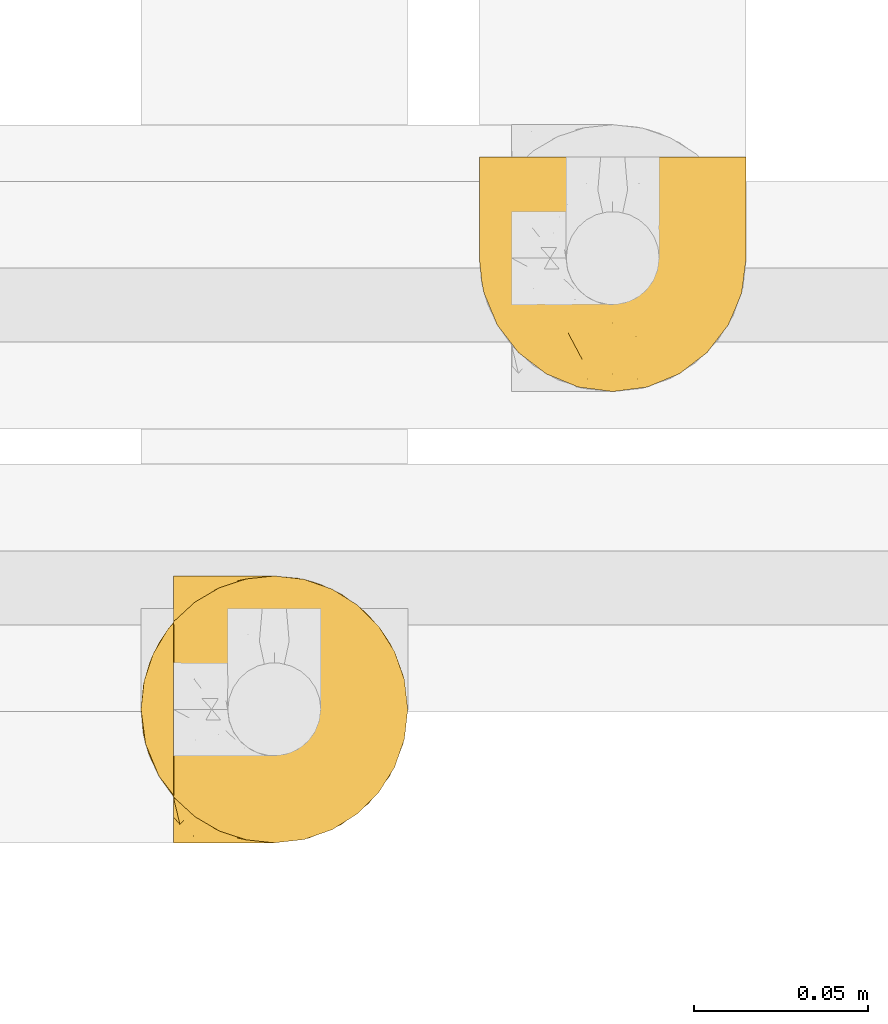
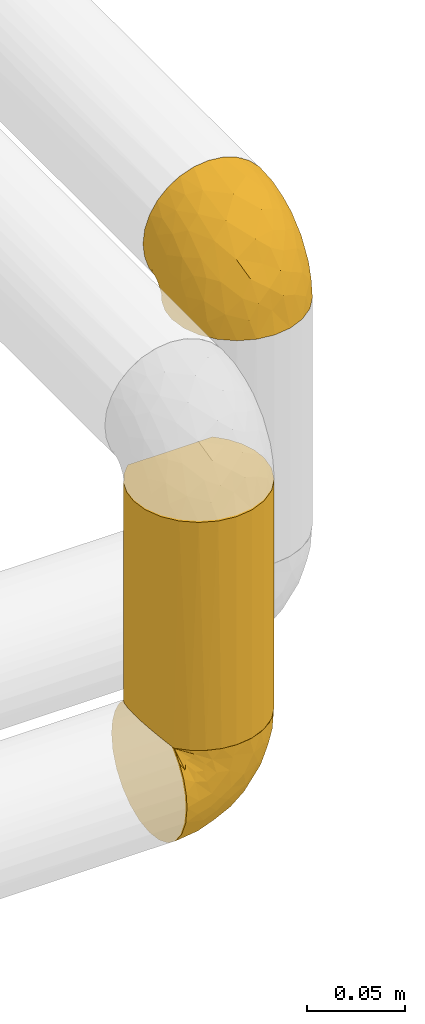
# One storey, part 90 of 827: 3 coverings.
"""IFC2X3 building model written with IfcOpenShell, lengths in millimetres."""

from ifc_helpers import new_model, entity, si_unit, converted_unit, derived_unit, direction, frame, origin, place, context, subcontext, project, spatial, faceted_brep, element, save


model = new_model("IFC2X3")

# Units and contexts
model_context = context("Model", 3, precision=0.01, world=origin(), true_north=direction((6.12303176911189e-17, 1.0)))
body_context = subcontext(model_context, "Body", "Model", "MODEL_VIEW")
ifc_project = project(units=[si_unit("LENGTHUNIT", "METRE", prefix="MILLI"), si_unit("AREAUNIT", "SQUARE_METRE"), si_unit("VOLUMEUNIT", "CUBIC_METRE"), converted_unit("PLANEANGLEUNIT", "DEGREE", entity("IfcRatioMeasure", 0.0174532925199433), si_unit("PLANEANGLEUNIT", "RADIAN"), dimensions=[0, 0, 0, 0, 0, 0, 0]), si_unit("MASSUNIT", "GRAM", prefix="KILO"), derived_unit("MASSDENSITYUNIT", [(si_unit("MASSUNIT", "GRAM", prefix="KILO"), 1), (si_unit("LENGTHUNIT", "METRE"), -3)]), derived_unit("MOMENTOFINERTIAUNIT", [(si_unit("LENGTHUNIT", "METRE"), 4)]), si_unit("TIMEUNIT", "SECOND"), si_unit("FREQUENCYUNIT", "HERTZ"), si_unit("THERMODYNAMICTEMPERATUREUNIT", "DEGREE_CELSIUS"), derived_unit("THERMALTRANSMITTANCEUNIT", [(si_unit("MASSUNIT", "GRAM", prefix="KILO"), 1), (si_unit("THERMODYNAMICTEMPERATUREUNIT", "KELVIN"), -1), (si_unit("TIMEUNIT", "SECOND"), -3)]), derived_unit("VOLUMETRICFLOWRATEUNIT", [(si_unit("LENGTHUNIT", "METRE"), 3), (si_unit("TIMEUNIT", "SECOND"), -1)]), derived_unit("MASSFLOWRATEUNIT", [(si_unit("MASSUNIT", "GRAM", prefix="KILO"), 1), (si_unit("TIMEUNIT", "SECOND"), -1)]), derived_unit("ROTATIONALFREQUENCYUNIT", [(si_unit("TIMEUNIT", "SECOND"), -1)]), si_unit("ELECTRICCURRENTUNIT", "AMPERE"), si_unit("ELECTRICVOLTAGEUNIT", "VOLT"), si_unit("POWERUNIT", "WATT"), si_unit("FORCEUNIT", "NEWTON", prefix="KILO"), si_unit("ILLUMINANCEUNIT", "LUX"), si_unit("LUMINOUSFLUXUNIT", "LUMEN"), si_unit("LUMINOUSINTENSITYUNIT", "CANDELA"), derived_unit("USERDEFINED", [(si_unit("MASSUNIT", "GRAM", prefix="KILO"), -1), (si_unit("LENGTHUNIT", "METRE"), -2), (si_unit("TIMEUNIT", "SECOND"), 3), (si_unit("LUMINOUSFLUXUNIT", "LUMEN"), 1)]), derived_unit("LINEARVELOCITYUNIT", [(si_unit("LENGTHUNIT", "METRE"), 1), (si_unit("TIMEUNIT", "SECOND"), -1)]), si_unit("PRESSUREUNIT", "PASCAL"), derived_unit("USERDEFINED", [(si_unit("LENGTHUNIT", "METRE"), -2), (si_unit("MASSUNIT", "GRAM", prefix="KILO"), 1), (si_unit("TIMEUNIT", "SECOND"), -2)]), derived_unit("LINEARFORCEUNIT", [(si_unit("MASSUNIT", "GRAM", prefix="KILO"), 1), (si_unit("LENGTHUNIT", "METRE"), 1), (si_unit("TIMEUNIT", "SECOND"), -2), (si_unit("LENGTHUNIT", "METRE"), -1)]), derived_unit("PLANARFORCEUNIT", [(si_unit("MASSUNIT", "GRAM", prefix="KILO"), 1), (si_unit("LENGTHUNIT", "METRE"), 1), (si_unit("TIMEUNIT", "SECOND"), -2), (si_unit("LENGTHUNIT", "METRE"), -2)])], contexts=[model_context])

# Site, building, storey
site_placement = place(None, origin())
site = spatial("IfcSite", under=ifc_project, at=site_placement, CompositionType="ELEMENT")
building_placement = place(site_placement, origin())
building = spatial("IfcBuilding", under=site, at=building_placement, CompositionType="ELEMENT")
storey_placement = place(building_placement, frame((0.0, 0.0, 28200.0)))
storey = spatial("IfcBuildingStorey", under=building, at=storey_placement, Name="08", CompositionType="ELEMENT", Elevation=28200.0)

# Coverings
covering_1_placement = place(storey_placement, frame((18643.01, 12909.95, 2569.3)))
element("IfcCovering", 1, at=covering_1_placement, inside=storey, Name=":ADSK_", ObjectType=":ADSK_", PredefinedType="INSULATION", context=body_context, shape_type="Brep", body=[
    faceted_brep([(5.41, 69.15, 47.38), (9.99, 69.15, 54.67), (16.08, 69.15, 60.76), (23.37, 69.15, 65.34), (31.49, 69.15, 68.18), (40.05, 69.15, 69.15), (48.61, 69.15, 68.18), (56.73, 69.15, 65.33), (64.02, 69.15, 60.75), (70.11, 69.15, 54.66), (74.69, 69.15, 47.37), (77.53, 69.15, 39.25), (78.5, 69.15, 30.7), (77.63, 69.15, 22.59), (75.08, 69.15, 14.86), (70.97, 69.15, 7.84), (65.47, 69.15, 1.85), (63.27, 69.15, 1.85), (61.53, 69.15, 1.85), (59.57, 69.15, 1.85), (57.6, 69.15, 1.85), (55.63, 69.15, 1.85), (53.67, 69.15, 1.85), (51.7, 69.15, 1.85), (49.73, 69.15, 1.85), (47.54, 69.15, 1.85), (45.34, 69.15, 1.85), (43.15, 69.15, 1.85), (40.96, 69.15, 1.85), (38.76, 69.15, 1.85), (36.57, 69.15, 1.85), (34.37, 69.15, 1.85), (32.18, 69.15, 1.85), (29.98, 69.15, 1.85), (27.79, 69.15, 1.85), (25.6, 69.15, 1.85), (23.4, 69.15, 1.85), (21.21, 69.15, 1.85), (19.01, 69.15, 1.85), (16.82, 69.15, 1.85), (14.62, 69.15, 1.85), (9.12, 69.15, 7.85), (5.0, 69.15, 14.88), (2.46, 69.15, 22.61), (1.6, 69.15, 30.7), (2.56, 69.15, 39.26), (65.47, 68.89, 1.6), (70.97, 62.89, 1.6), (75.09, 55.87, 1.6), (77.63, 48.14, 1.6), (78.5, 40.05, 1.6), (77.19, 30.09, 1.6), (73.34, 20.82, 1.6), (67.23, 12.86, 1.6), (59.27, 6.75, 1.6), (50.0, 2.91, 1.6), (40.05, 1.6, 1.6), (30.09, 2.91, 1.6), (20.82, 6.75, 1.6), (12.86, 12.86, 1.6), (6.75, 20.82, 1.6), (2.91, 30.09, 1.6), (1.6, 40.05, 1.6), (2.46, 48.14, 1.6), (5.0, 55.87, 1.6), (9.12, 62.89, 1.6), (14.62, 68.89, 1.6), (16.82, 68.89, 1.6), (17.8, 68.89, 1.6), (19.39, 68.89, 1.6), (20.98, 68.89, 1.6), (22.57, 68.89, 1.6), (24.16, 68.89, 1.6), (25.75, 68.89, 1.6), (27.33, 68.89, 1.6), (28.92, 68.89, 1.6), (30.51, 68.89, 1.6), (32.1, 68.89, 1.6), (33.69, 68.89, 1.6), (35.28, 68.89, 1.6), (36.87, 68.89, 1.6), (38.46, 68.89, 1.6), (40.05, 68.89, 1.6), (41.63, 68.89, 1.6), (43.22, 68.89, 1.6), (44.81, 68.89, 1.6), (46.4, 68.89, 1.6), (47.99, 68.89, 1.6), (49.58, 68.89, 1.6), (51.17, 68.89, 1.6), (52.76, 68.89, 1.6), (54.72, 68.89, 1.6), (56.69, 68.89, 1.6), (58.88, 68.89, 1.6), (61.08, 68.89, 1.6), (63.27, 68.89, 1.6), (37.77, 68.97, 1.78), (36.07, 68.96, 1.77), (32.96, 68.97, 1.78), (31.36, 68.97, 1.77), (56.52, 68.98, 1.79), (54.96, 68.97, 1.78), (18.75, 68.96, 1.76), (58.07, 68.96, 1.77), (50.37, 68.96, 1.77), (23.36, 68.96, 1.76), (24.95, 68.96, 1.77), (42.43, 68.96, 1.77), (15.97, 69.0, 1.8), (51.96, 68.96, 1.76), (53.47, 68.96, 1.77), (48.63, 68.97, 1.78), (63.93, 68.96, 1.77), (40.93, 68.96, 1.77), (29.72, 68.96, 1.76), (62.4, 68.97, 1.77), (60.92, 68.97, 1.78), (17.31, 68.97, 1.77), (21.74, 68.96, 1.77), (34.56, 68.96, 1.77), (20.18, 68.97, 1.78), (14.62, 68.97, 1.77), (14.62, 69.02, 1.8), (14.62, 69.08, 1.82), (65.47, 68.97, 1.77), (65.47, 68.94, 1.72), (59.5, 68.96, 1.76), (47.1, 68.96, 1.77), (45.61, 68.95, 1.76), (28.18, 68.96, 1.77), (14.62, 68.92, 1.66), (14.62, 68.94, 1.72), (26.61, 68.98, 1.78), (65.47, 69.08, 1.82), (65.47, 69.02, 1.8), (39.32, 68.96, 1.77), (44.12, 68.97, 1.78), (65.47, 68.92, 1.66), (72.26, 61.33, 3.72), (76.57, 53.1, 7.41), (71.77, 63.33, 6.13), (77.9, 55.53, 19.34), (76.56, 63.33, 17.64), (78.5, 54.6, 26.8), (78.5, 41.99, 8.87), (75.52, 57.07, 9.2), (76.13, 57.95, 12.79), (77.81, 51.56, 14.62), (78.5, 41.58, 7.34), (72.4, 61.7, 5.33), (71.77, 65.0, 7.7), (72.25, 67.02, 9.41), (78.5, 61.87, 28.75), (78.5, 49.27, 21.47), (78.5, 43.94, 16.15), (75.75, 61.21, 14.14), (78.5, 63.4, 29.16), (50.46, 33.11, 57.02), (52.75, 52.82, 64.92), (40.05, 43.3, 64.0), (77.7, 33.73, 11.92), (77.66, 36.52, 19.16), (71.02, 24.87, 28.65), (63.45, 14.17, 24.62), (70.55, 18.43, 15.19), (75.57, 28.67, 18.36), (75.57, 26.0, 9.2), (72.61, 49.25, 46.98), (72.61, 59.72, 50.24), (67.24, 55.1, 56.1), (77.74, 44.72, 28.97), (57.43, 34.15, 54.46), (47.19, 5.25, 21.34), (54.76, 6.75, 18.4), (40.05, 55.54, 66.44), (63.45, 10.47, 12.07), (60.1, 25.49, 45.49), (63.72, 35.53, 50.57), (76.83, 48.22, 36.04), (76.34, 58.71, 42.07), (60.51, 57.42, 62.12), (72.59, 34.84, 37.37), (76.05, 36.87, 29.39), (66.15, 45.01, 53.59), (60.51, 44.4, 58.06), (51.88, 23.96, 49.27), (55.34, 11.2, 29.63), (48.67, 10.56, 33.21), (53.89, 16.81, 40.1), (46.73, 17.38, 44.08), (40.05, 21.38, 49.36), (40.05, 32.34, 56.68), (40.05, 4.3, 15.2), (63.95, 20.65, 35.57), (67.24, 29.66, 41.7), (69.62, 39.6, 46.4), (73.6, 42.55, 41.41), (40.05, 6.74, 27.45), (40.05, 14.06, 38.4), (4.52, 26.84, 12.99), (32.72, 5.28, 21.33), (27.18, 18.52, 42.89), (29.63, 33.13, 57.04), (12.86, 55.1, 56.11), (19.59, 57.43, 62.13), (9.54, 20.72, 21.89), (16.64, 11.46, 16.62), (17.48, 17.69, 32.9), (7.49, 49.26, 46.99), (7.49, 59.73, 50.25), (3.75, 58.71, 42.08), (20.75, 29.72, 49.91), (2.33, 35.35, 15.6), (1.6, 43.94, 16.15), (1.6, 41.99, 8.87), (1.6, 63.4, 29.16), (26.94, 4.93, 13.16), (9.54, 17.46, 10.83), (31.21, 10.94, 33.8), (25.33, 8.92, 25.02), (27.35, 52.83, 64.92), (8.17, 29.34, 32.83), (4.3, 30.26, 20.56), (19.59, 44.4, 58.07), (2.23, 39.06, 21.46), (2.45, 43.06, 28.1), (1.6, 54.6, 26.8), (1.6, 49.27, 21.47), (12.86, 42.69, 51.29), (3.27, 48.2, 36.04), (1.6, 61.87, 28.75), (2.29, 33.44, 8.45), (12.86, 29.67, 41.73), (6.89, 38.5, 39.27), (12.43, 23.35, 33.56), (4.1, 34.97, 27.29), (3.53, 53.1, 7.41), (6.88, 59.68, 3.51), (8.16, 62.19, 4.68), (9.02, 64.11, 5.52), (5.0, 57.97, 8.75), (3.96, 57.95, 12.79), (3.52, 63.33, 17.65), (2.4, 51.77, 13.9), (7.83, 67.02, 9.42), (8.32, 64.98, 7.68), (2.19, 55.53, 19.33), (4.34, 61.22, 14.13)], [[[0, 1, 2, 3, 4, 5, 6, 7, 8, 9, 10, 11, 12, 13, 14, 15, 16, 17, 18, 19, 20, 21, 22, 23, 24, 25, 26, 27, 28, 29, 30, 31, 32, 33, 34, 35, 36, 37, 38, 39, 40, 41, 42, 43, 44, 45]], [[46, 47, 48, 49, 50, 51, 52, 53, 54, 55, 56, 57, 58, 59, 60, 61, 62, 63, 64, 65, 66, 67, 68, 69, 70, 71, 72, 73, 74, 75, 76, 77, 78, 79, 80, 81, 82, 83, 84, 85, 86, 87, 88, 89, 90, 91, 92, 93, 94, 95]], [[96, 97, 30]], [[98, 77, 99]], [[100, 101, 21]], [[69, 68, 102]], [[20, 19, 103]], [[24, 23, 104]], [[20, 103, 100]], [[72, 105, 106]], [[84, 83, 107]], [[89, 88, 104]], [[108, 67, 66]], [[109, 110, 90]], [[111, 25, 24]], [[112, 17, 16]], [[82, 113, 83]], [[109, 23, 22]], [[114, 76, 75]], [[105, 36, 106]], [[104, 111, 24]], [[18, 115, 116]], [[97, 96, 80]], [[67, 108, 117]], [[105, 71, 118]], [[31, 97, 119]], [[102, 120, 69]], [[108, 121, 122, 123, 40]], [[112, 95, 115]], [[17, 115, 18]], [[94, 116, 115]], [[117, 68, 67]], [[38, 117, 39]], [[112, 124, 125]], [[17, 112, 115]], [[70, 120, 118]], [[39, 117, 108]], [[120, 38, 37]], [[120, 37, 118]], [[120, 70, 69]], [[116, 94, 126]], [[127, 86, 128]], [[117, 38, 102]], [[74, 129, 75]], [[99, 33, 32]], [[115, 95, 94]], [[39, 108, 40]], [[108, 66, 130, 131]], [[105, 72, 71]], [[118, 37, 36]], [[71, 70, 118]], [[35, 106, 36]], [[36, 105, 118]], [[35, 132, 106]], [[74, 73, 132]], [[106, 132, 73]], [[99, 114, 33]], [[132, 35, 34]], [[73, 72, 106]], [[95, 112, 46]], [[112, 16, 133, 134, 124]], [[129, 114, 75]], [[99, 76, 114]], [[114, 129, 33]], [[34, 33, 129]], [[78, 77, 98]], [[98, 119, 78]], [[129, 132, 34]], [[132, 129, 74]], [[79, 97, 80]], [[98, 99, 32]], [[98, 32, 31]], [[77, 76, 99]], [[97, 79, 119]], [[135, 96, 29]], [[30, 97, 31]], [[135, 29, 28]], [[81, 80, 96]], [[29, 96, 30]], [[31, 119, 98]], [[119, 79, 78]], [[96, 135, 81]], [[82, 81, 135]], [[113, 107, 83]], [[84, 107, 136]], [[107, 27, 136]], [[113, 28, 107]], [[27, 107, 28]], [[85, 84, 136]], [[136, 27, 26]], [[113, 135, 28]], [[135, 113, 82]], [[109, 89, 104]], [[86, 85, 128]], [[89, 109, 90]], [[111, 87, 127]], [[26, 128, 136]], [[88, 111, 104]], [[25, 111, 127]], [[22, 110, 109]], [[23, 109, 104]], [[110, 91, 90]], [[100, 92, 101]], [[110, 22, 101]], [[91, 110, 101]], [[116, 19, 18]], [[111, 88, 87]], [[126, 103, 19]], [[25, 127, 26]], [[86, 127, 87]], [[127, 128, 26]], [[136, 128, 85]], [[120, 102, 38]], [[117, 102, 68]], [[91, 101, 92]], [[21, 101, 22]], [[93, 92, 103]], [[100, 21, 20]], [[100, 103, 92]], [[126, 93, 103]], [[93, 126, 94]], [[116, 126, 19]], [[137, 138, 47]], [[48, 138, 139]], [[140, 125, 124]], [[141, 142, 143]], [[144, 49, 139]], [[145, 140, 146]], [[48, 139, 49]], [[139, 145, 147]], [[49, 144, 148, 50]], [[137, 125, 149]], [[14, 13, 142]], [[150, 146, 140]], [[149, 140, 145]], [[151, 150, 134]], [[151, 14, 142]], [[16, 15, 133]], [[13, 152, 142]], [[124, 150, 140]], [[141, 143, 153]], [[14, 151, 15]], [[15, 151, 133]], [[47, 46, 137]], [[139, 154, 144]], [[138, 48, 47]], [[125, 140, 149]], [[134, 133, 151]], [[146, 155, 141]], [[145, 146, 147]], [[149, 139, 138]], [[147, 153, 154]], [[147, 146, 141]], [[139, 147, 154]], [[139, 149, 145]], [[149, 138, 137]], [[147, 141, 153]], [[146, 150, 155]], [[151, 155, 150]], [[142, 141, 155]], [[13, 12, 156, 152]], [[152, 143, 142]], [[151, 142, 155]], [[150, 124, 134]], [[157, 158, 159]], [[160, 154, 161]], [[162, 163, 164]], [[165, 166, 160]], [[167, 168, 169]], [[153, 170, 161]], [[156, 12, 11]], [[158, 157, 171]], [[172, 55, 173]], [[158, 6, 174]], [[175, 54, 53]], [[52, 166, 164]], [[52, 164, 53]], [[54, 175, 173]], [[166, 52, 51]], [[176, 177, 171]], [[178, 143, 179]], [[156, 11, 179]], [[8, 7, 180]], [[169, 9, 8]], [[179, 143, 152, 156]], [[179, 11, 10]], [[168, 179, 10]], [[181, 162, 182]], [[179, 167, 178]], [[183, 184, 177]], [[183, 169, 184]], [[176, 171, 185]], [[172, 186, 187]], [[158, 7, 6]], [[159, 158, 174]], [[184, 180, 158]], [[54, 173, 55]], [[180, 169, 8]], [[188, 189, 187]], [[9, 168, 10]], [[186, 188, 187]], [[190, 157, 159, 191]], [[55, 172, 192]], [[176, 193, 194]], [[161, 170, 182]], [[162, 164, 165]], [[175, 164, 163]], [[51, 50, 148]], [[167, 195, 196]], [[178, 182, 170]], [[6, 5, 174]], [[158, 180, 7]], [[169, 180, 184]], [[169, 168, 9]], [[179, 168, 167]], [[182, 162, 165]], [[162, 194, 193]], [[161, 165, 160]], [[195, 181, 196]], [[192, 172, 197]], [[192, 56, 55]], [[189, 190, 198]], [[198, 197, 187]], [[172, 187, 197]], [[185, 189, 188]], [[198, 187, 189]], [[186, 172, 173]], [[173, 163, 186]], [[193, 186, 163]], [[176, 185, 188]], [[185, 157, 190]], [[188, 186, 193]], [[177, 176, 194]], [[188, 193, 176]], [[162, 193, 163]], [[195, 177, 194]], [[171, 177, 184]], [[181, 195, 194]], [[183, 167, 169]], [[162, 181, 194]], [[196, 182, 178]], [[158, 171, 184]], [[171, 157, 185]], [[177, 195, 183]], [[167, 183, 195]], [[182, 196, 181]], [[178, 170, 143]], [[178, 167, 196]], [[164, 175, 53]], [[173, 175, 163]], [[160, 51, 148]], [[164, 166, 165]], [[51, 160, 166]], [[160, 148, 144, 154]], [[153, 161, 154]], [[182, 165, 161]], [[190, 189, 185]], [[143, 170, 153]], [[60, 199, 61]], [[197, 200, 192]], [[201, 190, 202]], [[200, 57, 192]], [[203, 204, 2]], [[205, 206, 207]], [[208, 209, 210]], [[211, 207, 201]], [[212, 213, 214]], [[45, 215, 210]], [[216, 206, 58]], [[45, 44, 215]], [[59, 217, 60]], [[60, 217, 199]], [[0, 45, 210]], [[218, 201, 219]], [[202, 159, 220]], [[205, 221, 222]], [[223, 204, 203]], [[1, 203, 2]], [[57, 200, 216]], [[220, 3, 204]], [[220, 174, 4]], [[1, 0, 209]], [[212, 224, 213]], [[225, 226, 227]], [[228, 223, 203]], [[208, 210, 229]], [[210, 226, 229]], [[3, 220, 4]], [[58, 206, 59]], [[209, 203, 1]], [[202, 220, 223]], [[228, 203, 208]], [[202, 211, 201]], [[3, 2, 204]], [[202, 190, 191, 159]], [[210, 215, 230, 226]], [[199, 212, 231]], [[232, 233, 221]], [[233, 208, 229]], [[207, 206, 219]], [[217, 206, 205]], [[227, 224, 225]], [[233, 232, 228]], [[201, 207, 219]], [[234, 232, 221]], [[218, 219, 200]], [[202, 223, 211]], [[174, 220, 159]], [[174, 5, 4]], [[61, 231, 62]], [[220, 204, 223]], [[210, 209, 0]], [[203, 209, 208]], [[225, 233, 229]], [[224, 227, 213]], [[221, 233, 235]], [[57, 56, 192]], [[198, 218, 197]], [[200, 219, 216]], [[201, 198, 190]], [[197, 218, 200]], [[198, 201, 218]], [[206, 216, 219]], [[58, 57, 216]], [[231, 212, 214]], [[222, 212, 199]], [[228, 211, 223]], [[207, 211, 232]], [[62, 231, 214]], [[199, 231, 61]], [[233, 228, 208]], [[211, 228, 232]], [[222, 221, 235]], [[234, 205, 207]], [[206, 217, 59]], [[199, 217, 205]], [[205, 222, 199]], [[224, 222, 235]], [[222, 224, 212]], [[224, 235, 225]], [[233, 225, 235]], [[226, 225, 229]], [[205, 234, 221]], [[207, 232, 234]], [[63, 214, 236]], [[214, 213, 236]], [[214, 63, 62]], [[237, 236, 238]], [[238, 131, 130]], [[236, 237, 64]], [[239, 240, 241]], [[63, 236, 64]], [[130, 66, 65]], [[237, 130, 65]], [[242, 230, 43]], [[237, 65, 64]], [[239, 121, 131]], [[42, 242, 43]], [[241, 240, 243]], [[41, 123, 244]], [[43, 230, 215, 44]], [[244, 122, 245]], [[227, 246, 243]], [[241, 247, 245]], [[121, 239, 245]], [[41, 40, 123]], [[131, 238, 239]], [[244, 42, 41]], [[130, 237, 238]], [[240, 239, 238]], [[245, 239, 241]], [[247, 241, 246]], [[247, 244, 245]], [[238, 236, 240]], [[243, 236, 213]], [[236, 243, 240]], [[227, 226, 246]], [[243, 213, 227]], [[242, 246, 226]], [[243, 246, 241]], [[246, 242, 247]], [[244, 247, 242]], [[242, 226, 230]], [[42, 244, 242]], [[122, 244, 123]], [[122, 121, 245]], [[112, 125, 137, 46]], [[108, 131, 121]]]),
])
covering_2_placement = place(storey_placement, frame((18545.56, 12780.0, 2427.5)))
element("IfcCovering", 2, at=covering_2_placement, inside=storey, Name=":ADSK_", ObjectType=":ADSK_", PredefinedType="INSULATION", context=body_context, shape_type="Brep", body=[
    faceted_brep([(23.98, 5.09, 1.6), (16.91, 9.31, 1.6), (10.9, 14.94, 1.6), (10.9, 65.05, 1.6), (16.91, 70.68, 1.6), (23.98, 74.9, 1.6), (31.79, 77.51, 1.6), (40.0, 78.4, 1.6), (49.93, 77.09, 1.6), (59.2, 73.25, 1.6), (67.15, 67.15, 1.6), (73.25, 59.2, 1.6), (77.09, 49.93, 1.6), (78.4, 40.0, 1.6), (77.09, 30.06, 1.6), (73.25, 20.8, 1.6), (67.15, 12.84, 1.6), (59.2, 6.74, 1.6), (49.93, 2.9, 1.6), (40.0, 1.6, 1.6), (31.79, 2.48, 1.6), (2.9, 30.06, 143.4), (6.74, 20.8, 143.4), (12.84, 12.84, 143.4), (20.8, 6.74, 143.4), (30.06, 2.9, 143.4), (40.0, 1.6, 143.4), (49.93, 2.9, 143.4), (59.2, 6.74, 143.4), (67.15, 12.84, 143.4), (73.25, 20.8, 143.4), (77.09, 30.06, 143.4), (78.4, 40.0, 143.4), (77.51, 48.2, 143.4), (74.9, 56.01, 143.4), (70.68, 63.08, 143.4), (65.05, 69.1, 143.4), (14.94, 69.1, 143.4), (9.31, 63.08, 143.4), (5.09, 56.01, 143.4), (2.48, 48.2, 143.4), (1.6, 40.0, 143.4), (46.78, 77.79, 134.7), (53.36, 76.0, 136.5), (59.51, 73.07, 139.42), (40.0, 78.4, 134.1), (4.0, 26.63, 8.5), (2.2, 33.21, 10.29), (1.6, 40.0, 10.9), (6.92, 20.48, 5.57), (2.2, 46.78, 10.29), (4.0, 53.36, 8.5), (6.92, 59.51, 5.57), (20.48, 73.07, 139.42), (26.63, 76.0, 136.5), (33.21, 77.79, 134.7)], [[[0, 1, 2, 3, 4, 5, 6, 7, 8, 9, 10, 11, 12, 13, 14, 15, 16, 17, 18, 19, 20]], [[21, 22, 23, 24, 25, 26, 27, 28, 29, 30, 31, 32, 33, 34, 35, 36, 37, 38, 39, 40, 41]], [[42, 43, 8]], [[44, 36, 9]], [[43, 44, 9]], [[45, 42, 7]], [[7, 42, 8]], [[43, 9, 8]], [[36, 10, 9]], [[11, 35, 34]], [[12, 34, 33]], [[13, 33, 32]], [[10, 35, 11]], [[11, 34, 12]], [[33, 13, 12]], [[35, 10, 36]], [[14, 13, 32, 31]], [[15, 14, 31, 30]], [[30, 29, 16, 15]], [[18, 17, 28, 27]], [[19, 18, 27, 26]], [[29, 28, 17, 16]], [[20, 26, 25]], [[0, 25, 24]], [[1, 24, 23]], [[19, 26, 20]], [[20, 25, 0]], [[24, 1, 0]], [[23, 2, 1]], [[46, 22, 21]], [[21, 41, 47]], [[48, 47, 41]], [[49, 2, 22]], [[47, 46, 21]], [[49, 22, 46]], [[22, 2, 23]], [[50, 41, 40]], [[51, 40, 39]], [[52, 39, 38]], [[50, 48, 41]], [[52, 51, 39]], [[3, 52, 38]], [[50, 40, 51]], [[38, 37, 3]], [[37, 53, 4]], [[54, 55, 6]], [[53, 54, 5]], [[4, 53, 5]], [[55, 7, 6]], [[6, 5, 54]], [[7, 55, 45]], [[37, 4, 3]], [[50, 51, 52, 3, 2, 49, 46, 47, 48]], [[43, 42, 45, 55, 54, 53, 37, 36, 44]]]),
])
covering_3_placement = place(storey_placement, frame((18554.86, 12779.95, 2359.95)))
element("IfcCovering", 3, at=covering_3_placement, inside=storey, Name=":ADSK_", ObjectType=":ADSK_", PredefinedType="INSULATION", context=body_context, shape_type="Brep", body=[
    faceted_brep([(47.38, 5.41, 69.15), (54.67, 9.99, 69.15), (60.76, 16.08, 69.15), (65.34, 23.37, 69.15), (68.18, 31.49, 69.15), (69.15, 40.05, 69.15), (68.18, 48.61, 69.15), (65.33, 56.73, 69.15), (60.75, 64.02, 69.15), (54.66, 70.11, 69.15), (47.37, 74.69, 69.15), (39.25, 77.53, 69.15), (30.7, 78.5, 69.15), (22.59, 77.63, 69.15), (14.86, 75.08, 69.15), (7.84, 70.97, 69.15), (1.85, 65.47, 69.15), (1.85, 63.27, 69.15), (1.85, 61.53, 69.15), (1.85, 59.57, 69.15), (1.85, 57.6, 69.15), (1.85, 55.63, 69.15), (1.85, 53.67, 69.15), (1.85, 51.7, 69.15), (1.85, 49.73, 69.15), (1.85, 47.54, 69.15), (1.85, 45.34, 69.15), (1.85, 43.15, 69.15), (1.85, 40.96, 69.15), (1.85, 38.76, 69.15), (1.85, 36.57, 69.15), (1.85, 34.37, 69.15), (1.85, 32.18, 69.15), (1.85, 29.98, 69.15), (1.85, 27.79, 69.15), (1.85, 25.6, 69.15), (1.85, 23.4, 69.15), (1.85, 21.21, 69.15), (1.85, 19.01, 69.15), (1.85, 16.82, 69.15), (1.85, 14.62, 69.15), (7.85, 9.12, 69.15), (14.88, 5.0, 69.15), (22.61, 2.46, 69.15), (30.7, 1.6, 69.15), (39.26, 2.56, 69.15), (1.6, 65.47, 68.89), (1.6, 70.97, 62.89), (1.6, 75.09, 55.87), (1.6, 77.63, 48.14), (1.6, 78.5, 40.05), (1.6, 77.19, 30.09), (1.6, 73.34, 20.82), (1.6, 67.23, 12.86), (1.6, 59.27, 6.75), (1.6, 50.0, 2.91), (1.6, 40.05, 1.6), (1.6, 30.09, 2.91), (1.6, 20.82, 6.75), (1.6, 12.86, 12.86), (1.6, 6.75, 20.82), (1.6, 2.91, 30.09), (1.6, 1.6, 40.05), (1.6, 2.46, 48.14), (1.6, 5.0, 55.87), (1.6, 9.12, 62.89), (1.6, 14.62, 68.89), (1.6, 16.82, 68.89), (1.6, 17.8, 68.89), (1.6, 19.39, 68.89), (1.6, 20.98, 68.89), (1.6, 22.57, 68.89), (1.6, 24.16, 68.89), (1.6, 25.75, 68.89), (1.6, 27.33, 68.89), (1.6, 28.92, 68.89), (1.6, 30.51, 68.89), (1.6, 32.1, 68.89), (1.6, 33.69, 68.89), (1.6, 35.28, 68.89), (1.6, 36.87, 68.89), (1.6, 38.46, 68.89), (1.6, 40.05, 68.89), (1.6, 41.63, 68.89), (1.6, 43.22, 68.89), (1.6, 44.81, 68.89), (1.6, 46.4, 68.89), (1.6, 47.99, 68.89), (1.6, 49.58, 68.89), (1.6, 51.17, 68.89), (1.6, 52.76, 68.89), (1.6, 54.72, 68.89), (1.6, 56.69, 68.89), (1.6, 58.88, 68.89), (1.6, 61.08, 68.89), (1.6, 63.27, 68.89), (1.78, 37.77, 68.97), (1.77, 36.07, 68.96), (1.78, 32.96, 68.97), (1.77, 31.36, 68.97), (1.79, 56.52, 68.98), (1.78, 54.96, 68.97), (1.76, 18.75, 68.96), (1.77, 58.07, 68.96), (1.77, 50.37, 68.96), (1.76, 23.36, 68.96), (1.77, 24.95, 68.96), (1.77, 42.43, 68.96), (1.8, 15.97, 69.0), (1.76, 51.96, 68.96), (1.77, 53.47, 68.96), (1.78, 48.63, 68.97), (1.77, 63.93, 68.96), (1.77, 40.93, 68.96), (1.76, 29.72, 68.96), (1.77, 62.4, 68.97), (1.78, 60.92, 68.97), (1.77, 17.31, 68.97), (1.77, 21.74, 68.96), (1.77, 34.56, 68.96), (1.78, 20.18, 68.97), (1.77, 14.62, 68.97), (1.8, 14.62, 69.02), (1.82, 14.62, 69.08), (1.77, 65.47, 68.97), (1.72, 65.47, 68.94), (1.66, 65.47, 68.92), (1.76, 59.5, 68.96), (1.77, 47.1, 68.96), (1.76, 45.61, 68.95), (1.77, 28.18, 68.96), (1.66, 14.62, 68.92), (1.72, 14.62, 68.94), (1.78, 26.61, 68.98), (1.82, 65.47, 69.08), (1.8, 65.47, 69.02), (1.77, 39.32, 68.96), (1.78, 44.12, 68.97), (3.72, 72.26, 61.33), (7.41, 76.57, 53.1), (6.13, 71.77, 63.33), (21.47, 78.5, 49.27), (19.34, 77.9, 55.53), (26.8, 78.5, 54.6), (8.87, 78.5, 41.99), (9.2, 75.52, 57.07), (12.79, 76.13, 57.95), (14.62, 77.81, 51.56), (7.34, 78.5, 41.58), (5.33, 72.4, 61.7), (17.64, 76.56, 63.33), (7.7, 71.77, 65.0), (9.41, 72.25, 67.02), (28.75, 78.5, 61.87), (16.15, 78.5, 43.94), (14.14, 75.75, 61.21), (29.16, 78.5, 63.4), (57.02, 50.46, 33.11), (64.92, 52.75, 52.82), (64.0, 40.05, 43.3), (11.92, 77.7, 33.73), (19.16, 77.66, 36.52), (28.65, 71.02, 24.87), (24.62, 63.45, 14.17), (15.19, 70.55, 18.43), (18.36, 75.57, 28.67), (9.2, 75.57, 26.0), (46.98, 72.61, 49.25), (50.24, 72.61, 59.72), (56.1, 67.24, 55.1), (28.97, 77.74, 44.72), (54.46, 57.43, 34.15), (21.34, 47.19, 5.25), (18.4, 54.76, 6.75), (66.44, 40.05, 55.54), (12.07, 63.45, 10.47), (45.49, 60.1, 25.49), (50.57, 63.72, 35.53), (36.04, 76.83, 48.22), (42.07, 76.34, 58.71), (62.12, 60.51, 57.42), (37.37, 72.59, 34.84), (29.39, 76.05, 36.87), (53.59, 66.15, 45.01), (58.06, 60.51, 44.4), (49.27, 51.88, 23.96), (29.63, 55.34, 11.2), (33.21, 48.67, 10.56), (40.1, 53.89, 16.81), (44.08, 46.73, 17.38), (49.36, 40.05, 21.38), (56.68, 40.05, 32.34), (15.2, 40.05, 4.3), (35.57, 63.95, 20.65), (41.7, 67.24, 29.66), (46.4, 69.62, 39.6), (41.41, 73.6, 42.55), (27.45, 40.05, 6.74), (38.4, 40.05, 14.06), (12.99, 4.52, 26.84), (21.33, 32.72, 5.28), (42.89, 27.18, 18.52), (57.04, 29.63, 33.13), (56.11, 12.86, 55.1), (62.13, 19.59, 57.43), (21.89, 9.54, 20.72), (16.62, 16.64, 11.46), (32.9, 17.48, 17.69), (46.99, 7.49, 49.26), (50.25, 7.49, 59.73), (42.08, 3.75, 58.71), (49.91, 20.75, 29.72), (15.6, 2.33, 35.35), (16.15, 1.6, 43.94), (8.87, 1.6, 41.99), (29.16, 1.6, 63.4), (13.16, 26.94, 4.93), (10.83, 9.54, 17.46), (33.8, 31.21, 10.94), (25.02, 25.33, 8.92), (64.92, 27.35, 52.83), (32.83, 8.17, 29.34), (20.56, 4.3, 30.26), (58.07, 19.59, 44.4), (21.46, 2.23, 39.06), (28.1, 2.45, 43.06), (26.8, 1.6, 54.6), (21.47, 1.6, 49.27), (51.29, 12.86, 42.69), (36.04, 3.27, 48.2), (28.75, 1.6, 61.87), (8.45, 2.29, 33.44), (41.73, 12.86, 29.67), (39.27, 6.89, 38.5), (33.56, 12.43, 23.35), (27.29, 4.1, 34.97), (7.41, 3.53, 53.1), (3.51, 6.88, 59.68), (4.68, 8.16, 62.19), (5.52, 9.02, 64.11), (8.75, 5.0, 57.97), (12.79, 3.96, 57.95), (17.65, 3.52, 63.33), (13.9, 2.4, 51.77), (9.42, 7.83, 67.02), (7.68, 8.32, 64.98), (19.33, 2.19, 55.53), (14.13, 4.34, 61.22)], [[[0, 1, 2, 3, 4, 5, 6, 7, 8, 9, 10, 11, 12, 13, 14, 15, 16, 17, 18, 19, 20, 21, 22, 23, 24, 25, 26, 27, 28, 29, 30, 31, 32, 33, 34, 35, 36, 37, 38, 39, 40, 41, 42, 43, 44, 45]], [[46, 47, 48, 49, 50, 51, 52, 53, 54, 55, 56, 57, 58, 59, 60, 61, 62, 63, 64, 65, 66, 67, 68, 69, 70, 71, 72, 73, 74, 75, 76, 77, 78, 79, 80, 81, 82, 83, 84, 85, 86, 87, 88, 89, 90, 91, 92, 93, 94, 95]], [[96, 97, 30]], [[98, 77, 99]], [[100, 101, 21]], [[69, 68, 102]], [[20, 19, 103]], [[24, 23, 104]], [[20, 103, 100]], [[72, 105, 106]], [[84, 83, 107]], [[89, 88, 104]], [[108, 67, 66]], [[109, 110, 90]], [[111, 25, 24]], [[112, 17, 16]], [[82, 113, 83]], [[109, 23, 22]], [[114, 76, 75]], [[105, 36, 106]], [[104, 111, 24]], [[18, 115, 116]], [[97, 96, 80]], [[67, 108, 117]], [[105, 71, 118]], [[31, 97, 119]], [[102, 120, 69]], [[108, 121, 122, 123, 40]], [[112, 95, 115]], [[17, 115, 18]], [[94, 116, 115]], [[117, 68, 67]], [[38, 117, 39]], [[112, 124, 125, 126, 46]], [[17, 112, 115]], [[70, 120, 118]], [[39, 117, 108]], [[120, 38, 37]], [[120, 37, 118]], [[120, 70, 69]], [[116, 94, 127]], [[128, 86, 129]], [[117, 38, 102]], [[74, 130, 75]], [[99, 33, 32]], [[115, 95, 94]], [[39, 108, 40]], [[108, 66, 131, 132, 121]], [[105, 72, 71]], [[118, 37, 36]], [[71, 70, 118]], [[35, 106, 36]], [[36, 105, 118]], [[35, 133, 106]], [[74, 73, 133]], [[106, 133, 73]], [[99, 114, 33]], [[133, 35, 34]], [[73, 72, 106]], [[95, 112, 46]], [[112, 16, 134, 135, 124]], [[130, 114, 75]], [[99, 76, 114]], [[114, 130, 33]], [[34, 33, 130]], [[78, 77, 98]], [[98, 119, 78]], [[130, 133, 34]], [[133, 130, 74]], [[79, 97, 80]], [[98, 99, 32]], [[98, 32, 31]], [[77, 76, 99]], [[97, 79, 119]], [[136, 96, 29]], [[30, 97, 31]], [[136, 29, 28]], [[81, 80, 96]], [[29, 96, 30]], [[31, 119, 98]], [[119, 79, 78]], [[96, 136, 81]], [[82, 81, 136]], [[113, 107, 83]], [[84, 107, 137]], [[107, 27, 137]], [[113, 28, 107]], [[27, 107, 28]], [[85, 84, 137]], [[137, 27, 26]], [[113, 136, 28]], [[136, 113, 82]], [[109, 89, 104]], [[86, 85, 129]], [[89, 109, 90]], [[111, 87, 128]], [[26, 129, 137]], [[88, 111, 104]], [[25, 111, 128]], [[22, 110, 109]], [[23, 109, 104]], [[110, 91, 90]], [[100, 92, 101]], [[110, 22, 101]], [[91, 110, 101]], [[116, 19, 18]], [[111, 88, 87]], [[127, 103, 19]], [[25, 128, 26]], [[86, 128, 87]], [[128, 129, 26]], [[137, 129, 85]], [[120, 102, 38]], [[117, 102, 68]], [[91, 101, 92]], [[21, 101, 22]], [[93, 92, 103]], [[100, 21, 20]], [[100, 103, 92]], [[127, 93, 103]], [[93, 127, 94]], [[116, 127, 19]], [[126, 138, 47]], [[48, 138, 139]], [[140, 125, 124]], [[141, 142, 143]], [[144, 49, 139]], [[145, 140, 146]], [[48, 139, 49]], [[139, 145, 147]], [[49, 144, 148, 50]], [[126, 125, 149]], [[14, 13, 150]], [[151, 146, 140]], [[149, 140, 145]], [[152, 151, 135]], [[152, 14, 150]], [[16, 15, 134]], [[13, 153, 150]], [[124, 151, 140]], [[141, 147, 142]], [[14, 152, 15]], [[15, 152, 134]], [[47, 46, 126]], [[139, 154, 144]], [[138, 48, 47]], [[125, 140, 149]], [[135, 134, 152]], [[146, 155, 142]], [[145, 146, 147]], [[149, 139, 138]], [[147, 141, 154]], [[147, 146, 142]], [[139, 147, 154]], [[139, 149, 145]], [[149, 138, 126]], [[155, 146, 151]], [[150, 143, 142]], [[152, 155, 151]], [[150, 142, 155]], [[13, 12, 156, 153]], [[153, 143, 150]], [[152, 150, 155]], [[151, 124, 135]], [[157, 158, 159]], [[160, 154, 161]], [[162, 163, 164]], [[165, 166, 160]], [[167, 168, 169]], [[141, 170, 161]], [[156, 12, 11]], [[158, 157, 171]], [[172, 55, 173]], [[158, 6, 174]], [[175, 54, 53]], [[52, 166, 164]], [[52, 164, 53]], [[54, 175, 173]], [[166, 52, 51]], [[176, 177, 171]], [[178, 143, 179]], [[156, 11, 179]], [[8, 7, 180]], [[169, 9, 8]], [[179, 143, 153, 156]], [[179, 11, 10]], [[168, 179, 10]], [[181, 162, 182]], [[179, 167, 178]], [[183, 184, 177]], [[183, 169, 184]], [[176, 171, 185]], [[172, 186, 187]], [[158, 7, 6]], [[159, 158, 174]], [[184, 180, 158]], [[54, 173, 55]], [[180, 169, 8]], [[188, 189, 187]], [[9, 168, 10]], [[186, 188, 187]], [[190, 157, 159, 191]], [[55, 172, 192]], [[176, 193, 194]], [[161, 170, 182]], [[162, 164, 165]], [[175, 164, 163]], [[51, 50, 148]], [[167, 195, 196]], [[178, 182, 170]], [[6, 5, 174]], [[158, 180, 7]], [[169, 180, 184]], [[169, 168, 9]], [[179, 168, 167]], [[182, 162, 165]], [[162, 194, 193]], [[161, 165, 160]], [[195, 181, 196]], [[192, 172, 197]], [[192, 56, 55]], [[189, 190, 198]], [[198, 197, 187]], [[172, 187, 197]], [[185, 189, 188]], [[198, 187, 189]], [[186, 172, 173]], [[173, 163, 186]], [[193, 186, 163]], [[176, 185, 188]], [[185, 157, 190]], [[188, 186, 193]], [[177, 176, 194]], [[188, 193, 176]], [[162, 193, 163]], [[195, 177, 194]], [[171, 177, 184]], [[181, 195, 194]], [[183, 167, 169]], [[162, 181, 194]], [[196, 182, 178]], [[158, 171, 184]], [[171, 157, 185]], [[177, 195, 183]], [[167, 183, 195]], [[182, 196, 181]], [[178, 170, 143]], [[178, 167, 196]], [[164, 175, 53]], [[173, 175, 163]], [[160, 51, 148]], [[164, 166, 165]], [[51, 160, 166]], [[160, 148, 144, 154]], [[141, 161, 154]], [[182, 165, 161]], [[190, 189, 185]], [[143, 170, 141]], [[60, 199, 61]], [[197, 200, 192]], [[201, 190, 202]], [[200, 57, 192]], [[203, 204, 2]], [[205, 206, 207]], [[208, 209, 210]], [[211, 207, 201]], [[212, 213, 214]], [[45, 215, 210]], [[216, 206, 58]], [[45, 44, 215]], [[59, 217, 60]], [[60, 217, 199]], [[0, 45, 210]], [[218, 201, 219]], [[202, 159, 220]], [[205, 221, 222]], [[223, 204, 203]], [[1, 203, 2]], [[57, 200, 216]], [[220, 3, 204]], [[220, 174, 4]], [[1, 0, 209]], [[212, 224, 213]], [[225, 226, 227]], [[228, 223, 203]], [[208, 210, 229]], [[210, 226, 229]], [[3, 220, 4]], [[58, 206, 59]], [[209, 203, 1]], [[202, 220, 223]], [[228, 203, 208]], [[202, 211, 201]], [[3, 2, 204]], [[202, 190, 191, 159]], [[210, 215, 230, 226]], [[199, 212, 231]], [[232, 233, 221]], [[233, 208, 229]], [[207, 206, 219]], [[217, 206, 205]], [[227, 224, 225]], [[233, 232, 228]], [[201, 207, 219]], [[234, 232, 221]], [[218, 219, 200]], [[202, 223, 211]], [[174, 220, 159]], [[174, 5, 4]], [[61, 231, 62]], [[220, 204, 223]], [[210, 209, 0]], [[203, 209, 208]], [[225, 233, 229]], [[224, 227, 213]], [[221, 233, 235]], [[57, 56, 192]], [[198, 218, 197]], [[200, 219, 216]], [[201, 198, 190]], [[197, 218, 200]], [[198, 201, 218]], [[206, 216, 219]], [[58, 57, 216]], [[231, 212, 214]], [[222, 212, 199]], [[228, 211, 223]], [[207, 211, 232]], [[62, 231, 214]], [[199, 231, 61]], [[233, 228, 208]], [[211, 228, 232]], [[222, 221, 235]], [[234, 205, 207]], [[206, 217, 59]], [[199, 217, 205]], [[205, 222, 199]], [[224, 222, 235]], [[222, 224, 212]], [[224, 235, 225]], [[233, 225, 235]], [[226, 225, 229]], [[205, 234, 221]], [[207, 232, 234]], [[63, 214, 236]], [[214, 213, 236]], [[214, 63, 62]], [[237, 236, 238]], [[238, 132, 131]], [[236, 237, 64]], [[239, 240, 241]], [[63, 236, 64]], [[131, 66, 65]], [[237, 131, 65]], [[242, 230, 43]], [[237, 65, 64]], [[239, 121, 132]], [[42, 242, 43]], [[241, 240, 243]], [[41, 123, 244]], [[43, 230, 215, 44]], [[244, 122, 245]], [[227, 246, 243]], [[241, 247, 245]], [[121, 239, 245]], [[41, 40, 123]], [[132, 238, 239]], [[244, 42, 41]], [[131, 237, 238]], [[240, 239, 238]], [[245, 239, 241]], [[247, 241, 246]], [[247, 244, 245]], [[238, 236, 240]], [[243, 236, 213]], [[236, 243, 240]], [[227, 226, 246]], [[243, 213, 227]], [[242, 246, 226]], [[243, 246, 241]], [[246, 242, 247]], [[244, 247, 242]], [[242, 226, 230]], [[42, 244, 242]], [[122, 244, 123]], [[122, 121, 245]]]),
])

save(model, "model.ifc")
